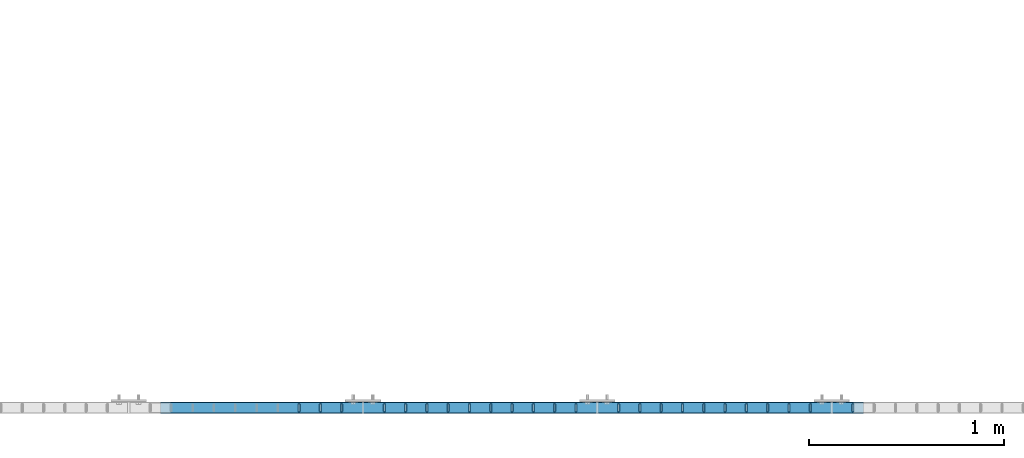
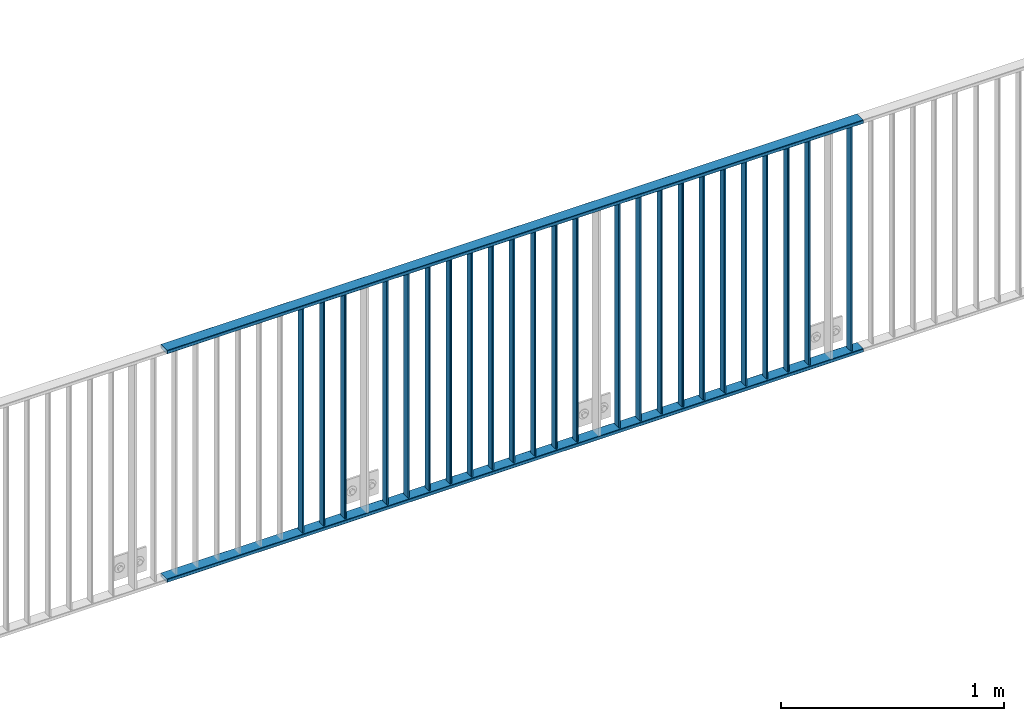
# One storey, part 29 of 156: 26 beams, 1 element without a shape of its own.
"""IFC2X3 building model written with IfcOpenShell, lengths in millimetres."""

from ifc_helpers import new_model, si_unit, frame, origin_with_axes, origin_2d_with_axis, place, context, subcontext, project, spatial, hollow_rectangle, extrude, clip, halfspace, material, type_object, element, aggregate, save


model = new_model("IFC2X3")

# Units and contexts
model_context = context("Model", 3, precision=1e-05, world=origin_with_axes())
body_context = subcontext(model_context, "Body", "Model", "MODEL_VIEW")
ifc_project = project(units=[si_unit("LENGTHUNIT", "METRE", prefix="MILLI"), si_unit("AREAUNIT", "SQUARE_METRE"), si_unit("VOLUMEUNIT", "CUBIC_METRE"), si_unit("MASSUNIT", "GRAM", prefix="KILO"), si_unit("TIMEUNIT", "SECOND"), si_unit("PLANEANGLEUNIT", "RADIAN"), si_unit("SOLIDANGLEUNIT", "STERADIAN"), si_unit("THERMODYNAMICTEMPERATUREUNIT", "DEGREE_CELSIUS"), si_unit("LUMINOUSINTENSITYUNIT", "LUMEN")], contexts=[model_context])

# Site, building, storey
site_placement = place(None, origin_with_axes())
site = spatial("IfcSite", under=ifc_project, at=site_placement, CompositionType="ELEMENT")
building_placement = place(site_placement, origin_with_axes())
building = spatial("IfcBuilding", under=site, at=building_placement, Name="Undefined", CompositionType="ELEMENT")
storey_placement = place(building_placement, origin_with_axes())
storey = spatial("IfcBuildingStorey", under=building, at=storey_placement, Name="Undefined", CompositionType="ELEMENT", Elevation=0.0)

# Assembly, beams
assembly_placement = place(storey_placement, origin_with_axes())
assembly = element("IfcElementAssembly", 1, at=assembly_placement, inside=storey, AssemblyPlace="NOTDEFINED", PredefinedType="RIGID_FRAME")
ifc_material = material(Name="STEEL/S235JR")
beam_type_1 = type_object("IfcBeamType", Name="K60/20/2", PredefinedType="NOTDEFINED")
beam_1_placement = place(assembly_placement, frame((39563.0399999997, 8480.00209045411, 2740.0), z_axis=(0.0, 1.0, 0.0), x_axis=(1.0, 0.0, 0.0)))
beam_1 = element("IfcBeam", 2, at=beam_1_placement, type_object=beam_type_1, material=ifc_material, ObjectType="K60/20/2", context=body_context, shape_type="SweptSolid", body=[
    extrude(hollow_rectangle(XDim=20.0, YDim=60.0, WallThickness=2.0, InnerFilletRadius=2.0, OuterFilletRadius=4.0, at=origin_2d_with_axis()), frame((3600.0, 0.0, 0.0), z_axis=(-1.0, 0.0, 0.0), x_axis=(0.0, -1.0, 0.0)), (0.0, 0.0, 1.0), 3600.0),
])
beam_2_placement = place(assembly_placement, frame((39563.0399999997, 8479.98209037835, 3990.0), z_axis=(0.0, 1.0, 0.0), x_axis=(1.0, 0.0, 0.0)))
beam_2 = element("IfcBeam", 3, at=beam_2_placement, type_object=beam_type_1, material=ifc_material, ObjectType="K60/20/2", context=body_context, shape_type="SweptSolid", body=[
    extrude(hollow_rectangle(XDim=20.0, YDim=60.0, WallThickness=2.0, InnerFilletRadius=2.0, OuterFilletRadius=4.0, at=origin_2d_with_axis()), frame((3600.0, 0.0, 0.0), z_axis=(-1.0, 0.0, 0.0), x_axis=(0.0, -1.0, 0.0)), (0.0, 0.0, 1.0), 3600.0),
])
beam_type_2 = type_object("IfcBeamType", Name="K40/10/1.5", PredefinedType="NOTDEFINED")
beam_3_placement = place(assembly_placement, frame((43109.089999999, 8480.00209765299, 3980.00000000003), z_axis=(0.0, 1.0, 0.0), x_axis=(0.0, 0.0, -1.0)))
beam_3 = element("IfcBeam", 4, at=beam_3_placement, type_object=beam_type_2, material=ifc_material, ObjectType="K40/10/1.5", context=body_context, shape_type="Clipping", body=[
    clip(extrude(hollow_rectangle(XDim=10.0, YDim=40.0, WallThickness=1.5, InnerFilletRadius=1.5, OuterFilletRadius=3.0, at=origin_2d_with_axis()), frame((1230.0, 0.0, 0.0), z_axis=(-1.0, 0.0, 0.0), x_axis=(0.0, -1.0, 0.0)), (0.0, 0.0, 1.0), 1230.0), halfspace(frame((-6.99999999997453, -4.34248751950508, 47.3810900558092), z_axis=(-1.0, 0.0, 0.0), x_axis=(0.0, 0.7683548141934, -0.640024124159258)), False)),
])
beam_4_placement = place(assembly_placement, frame((42890.899999999, 8480.00209765299, 3980.00000000003), z_axis=(0.0, 1.0, 0.0), x_axis=(0.0, 0.0, -1.0)))
beam_4 = element("IfcBeam", 5, at=beam_4_placement, type_object=beam_type_2, material=ifc_material, ObjectType="K40/10/1.5", context=body_context, shape_type="Clipping", body=[
    clip(extrude(hollow_rectangle(XDim=10.0, YDim=40.0, WallThickness=1.5, InnerFilletRadius=1.5, OuterFilletRadius=3.0, at=origin_2d_with_axis()), frame((1230.0, 0.0, 0.0), z_axis=(-1.0, 0.0, 0.0), x_axis=(0.0, -1.0, 0.0)), (0.0, 0.0, 1.0), 1230.0), halfspace(frame((-6.99999999997453, -4.34248751950508, 47.3810900558092), z_axis=(-1.0, 0.0, 0.0), x_axis=(0.0, 0.7683548141934, -0.640024124159258)), False)),
])
beam_5_placement = place(assembly_placement, frame((42781.809999999, 8480.00209765299, 3980.00000000003), z_axis=(0.0, 1.0, 0.0), x_axis=(0.0, 0.0, -1.0)))
beam_5 = element("IfcBeam", 6, at=beam_5_placement, type_object=beam_type_2, material=ifc_material, ObjectType="K40/10/1.5", context=body_context, shape_type="Clipping", body=[
    clip(extrude(hollow_rectangle(XDim=10.0, YDim=40.0, WallThickness=1.5, InnerFilletRadius=1.5, OuterFilletRadius=3.0, at=origin_2d_with_axis()), frame((1230.0, 0.0, 0.0), z_axis=(-1.0, 0.0, 0.0), x_axis=(0.0, -1.0, 0.0)), (0.0, 0.0, 1.0), 1230.0), halfspace(frame((-6.99999999997453, -4.34248751950508, 47.3810900558092), z_axis=(-1.0, 0.0, 0.0), x_axis=(0.0, 0.7683548141934, -0.640024124159258)), False)),
])
beam_6_placement = place(assembly_placement, frame((42672.719999999, 8480.00209765299, 3980.00000000003), z_axis=(0.0, 1.0, 0.0), x_axis=(0.0, 0.0, -1.0)))
beam_6 = element("IfcBeam", 7, at=beam_6_placement, type_object=beam_type_2, material=ifc_material, ObjectType="K40/10/1.5", context=body_context, shape_type="Clipping", body=[
    clip(extrude(hollow_rectangle(XDim=10.0, YDim=40.0, WallThickness=1.5, InnerFilletRadius=1.5, OuterFilletRadius=3.0, at=origin_2d_with_axis()), frame((1230.0, 0.0, 0.0), z_axis=(-1.0, 0.0, 0.0), x_axis=(0.0, -1.0, 0.0)), (0.0, 0.0, 1.0), 1230.0), halfspace(frame((-6.99999999997453, -4.34248751950508, 47.3810900558092), z_axis=(-1.0, 0.0, 0.0), x_axis=(0.0, 0.7683548141934, -0.640024124159258)), False)),
])
beam_7_placement = place(assembly_placement, frame((42563.629999999, 8480.00209765299, 3980.00000000003), z_axis=(0.0, 1.0, 0.0), x_axis=(0.0, 0.0, -1.0)))
beam_7 = element("IfcBeam", 8, at=beam_7_placement, type_object=beam_type_2, material=ifc_material, ObjectType="K40/10/1.5", context=body_context, shape_type="Clipping", body=[
    clip(extrude(hollow_rectangle(XDim=10.0, YDim=40.0, WallThickness=1.5, InnerFilletRadius=1.5, OuterFilletRadius=3.0, at=origin_2d_with_axis()), frame((1230.0, 0.0, 0.0), z_axis=(-1.0, 0.0, 0.0), x_axis=(0.0, -1.0, 0.0)), (0.0, 0.0, 1.0), 1230.0), halfspace(frame((-6.99999999997453, -4.34248751950508, 47.3810900558092), z_axis=(-1.0, 0.0, 0.0), x_axis=(0.0, 0.7683548141934, -0.640024124159258)), False)),
])
beam_8_placement = place(assembly_placement, frame((42454.539999999, 8480.00209765299, 3980.00000000003), z_axis=(0.0, 1.0, 0.0), x_axis=(0.0, 0.0, -1.0)))
beam_8 = element("IfcBeam", 9, at=beam_8_placement, type_object=beam_type_2, material=ifc_material, ObjectType="K40/10/1.5", context=body_context, shape_type="Clipping", body=[
    clip(extrude(hollow_rectangle(XDim=10.0, YDim=40.0, WallThickness=1.5, InnerFilletRadius=1.5, OuterFilletRadius=3.0, at=origin_2d_with_axis()), frame((1230.0, 0.0, 0.0), z_axis=(-1.0, 0.0, 0.0), x_axis=(0.0, -1.0, 0.0)), (0.0, 0.0, 1.0), 1230.0), halfspace(frame((-6.99999999997453, -4.34248751950508, 47.3810900558092), z_axis=(-1.0, 0.0, 0.0), x_axis=(0.0, 0.7683548141934, -0.640024124159258)), False)),
])
beam_9_placement = place(assembly_placement, frame((42345.449999999, 8480.00209765299, 3980.00000000003), z_axis=(0.0, 1.0, 0.0), x_axis=(0.0, 0.0, -1.0)))
beam_9 = element("IfcBeam", 10, at=beam_9_placement, type_object=beam_type_2, material=ifc_material, ObjectType="K40/10/1.5", context=body_context, shape_type="Clipping", body=[
    clip(extrude(hollow_rectangle(XDim=10.0, YDim=40.0, WallThickness=1.5, InnerFilletRadius=1.5, OuterFilletRadius=3.0, at=origin_2d_with_axis()), frame((1230.0, 0.0, 0.0), z_axis=(-1.0, 0.0, 0.0), x_axis=(0.0, -1.0, 0.0)), (0.0, 0.0, 1.0), 1230.0), halfspace(frame((-6.99999999997453, -4.34248751950508, 47.3810900558092), z_axis=(-1.0, 0.0, 0.0), x_axis=(0.0, 0.7683548141934, -0.640024124159258)), False)),
])
beam_10_placement = place(assembly_placement, frame((42236.359999999, 8480.00209765299, 3980.00000000003), z_axis=(0.0, 1.0, 0.0), x_axis=(0.0, 0.0, -1.0)))
beam_10 = element("IfcBeam", 11, at=beam_10_placement, type_object=beam_type_2, material=ifc_material, ObjectType="K40/10/1.5", context=body_context, shape_type="Clipping", body=[
    clip(extrude(hollow_rectangle(XDim=10.0, YDim=40.0, WallThickness=1.5, InnerFilletRadius=1.5, OuterFilletRadius=3.0, at=origin_2d_with_axis()), frame((1230.0, 0.0, 0.0), z_axis=(-1.0, 0.0, 0.0), x_axis=(0.0, -1.0, 0.0)), (0.0, 0.0, 1.0), 1230.0), halfspace(frame((-6.99999999997453, -4.34248751950508, 47.3810900558092), z_axis=(-1.0, 0.0, 0.0), x_axis=(0.0, 0.7683548141934, -0.640024124159258)), False)),
])
beam_11_placement = place(assembly_placement, frame((42127.269999999, 8480.00209765299, 3980.00000000003), z_axis=(0.0, 1.0, 0.0), x_axis=(0.0, 0.0, -1.0)))
beam_11 = element("IfcBeam", 12, at=beam_11_placement, type_object=beam_type_2, material=ifc_material, ObjectType="K40/10/1.5", context=body_context, shape_type="Clipping", body=[
    clip(extrude(hollow_rectangle(XDim=10.0, YDim=40.0, WallThickness=1.5, InnerFilletRadius=1.5, OuterFilletRadius=3.0, at=origin_2d_with_axis()), frame((1230.0, 0.0, 0.0), z_axis=(-1.0, 0.0, 0.0), x_axis=(0.0, -1.0, 0.0)), (0.0, 0.0, 1.0), 1230.0), halfspace(frame((-6.99999999997453, -4.34248751950508, 47.3810900558092), z_axis=(-1.0, 0.0, 0.0), x_axis=(0.0, 0.7683548141934, -0.640024124159258)), False)),
])
beam_12_placement = place(assembly_placement, frame((42018.179999999, 8480.00209765299, 3980.00000000003), z_axis=(0.0, 1.0, 0.0), x_axis=(0.0, 0.0, -1.0)))
beam_12 = element("IfcBeam", 13, at=beam_12_placement, type_object=beam_type_2, material=ifc_material, ObjectType="K40/10/1.5", context=body_context, shape_type="Clipping", body=[
    clip(extrude(hollow_rectangle(XDim=10.0, YDim=40.0, WallThickness=1.5, InnerFilletRadius=1.5, OuterFilletRadius=3.0, at=origin_2d_with_axis()), frame((1230.0, 0.0, 0.0), z_axis=(-1.0, 0.0, 0.0), x_axis=(0.0, -1.0, 0.0)), (0.0, 0.0, 1.0), 1230.0), halfspace(frame((-6.99999999997453, -4.34248751950508, 47.3810900558092), z_axis=(-1.0, 0.0, 0.0), x_axis=(0.0, 0.7683548141934, -0.640024124159258)), False)),
])
beam_13_placement = place(assembly_placement, frame((41909.089999999, 8480.00209765299, 3980.00000000003), z_axis=(0.0, 1.0, 0.0), x_axis=(0.0, 0.0, -1.0)))
beam_13 = element("IfcBeam", 14, at=beam_13_placement, type_object=beam_type_2, material=ifc_material, ObjectType="K40/10/1.5", context=body_context, shape_type="Clipping", body=[
    clip(extrude(hollow_rectangle(XDim=10.0, YDim=40.0, WallThickness=1.5, InnerFilletRadius=1.5, OuterFilletRadius=3.0, at=origin_2d_with_axis()), frame((1230.0, 0.0, 0.0), z_axis=(-1.0, 0.0, 0.0), x_axis=(0.0, -1.0, 0.0)), (0.0, 0.0, 1.0), 1230.0), halfspace(frame((-6.99999999997453, -4.34248751950508, 47.3810900558092), z_axis=(-1.0, 0.0, 0.0), x_axis=(0.0, 0.7683548141934, -0.640024124159258)), False)),
])
beam_14_placement = place(assembly_placement, frame((41690.899999999, 8480.00209765299, 3980.00000000003), z_axis=(0.0, 1.0, 0.0), x_axis=(0.0, 0.0, -1.0)))
beam_14 = element("IfcBeam", 15, at=beam_14_placement, type_object=beam_type_2, material=ifc_material, ObjectType="K40/10/1.5", context=body_context, shape_type="Clipping", body=[
    clip(extrude(hollow_rectangle(XDim=10.0, YDim=40.0, WallThickness=1.5, InnerFilletRadius=1.5, OuterFilletRadius=3.0, at=origin_2d_with_axis()), frame((1230.0, 0.0, 0.0), z_axis=(-1.0, 0.0, 0.0), x_axis=(0.0, -1.0, 0.0)), (0.0, 0.0, 1.0), 1230.0), halfspace(frame((-6.99999999997453, -4.34248751950508, 47.3810900558092), z_axis=(-1.0, 0.0, 0.0), x_axis=(0.0, 0.7683548141934, -0.640024124159258)), False)),
])
beam_15_placement = place(assembly_placement, frame((41581.809999999, 8480.00209765299, 3980.00000000003), z_axis=(0.0, 1.0, 0.0), x_axis=(0.0, 0.0, -1.0)))
beam_15 = element("IfcBeam", 16, at=beam_15_placement, type_object=beam_type_2, material=ifc_material, ObjectType="K40/10/1.5", context=body_context, shape_type="Clipping", body=[
    clip(extrude(hollow_rectangle(XDim=10.0, YDim=40.0, WallThickness=1.5, InnerFilletRadius=1.5, OuterFilletRadius=3.0, at=origin_2d_with_axis()), frame((1230.0, 0.0, 0.0), z_axis=(-1.0, 0.0, 0.0), x_axis=(0.0, -1.0, 0.0)), (0.0, 0.0, 1.0), 1230.0), halfspace(frame((-6.99999999997453, -4.34248751950508, 47.3810900558092), z_axis=(-1.0, 0.0, 0.0), x_axis=(0.0, 0.7683548141934, -0.640024124159258)), False)),
])
beam_16_placement = place(assembly_placement, frame((41472.719999999, 8480.00209765299, 3980.00000000003), z_axis=(0.0, 1.0, 0.0), x_axis=(0.0, 0.0, -1.0)))
beam_16 = element("IfcBeam", 17, at=beam_16_placement, type_object=beam_type_2, material=ifc_material, ObjectType="K40/10/1.5", context=body_context, shape_type="Clipping", body=[
    clip(extrude(hollow_rectangle(XDim=10.0, YDim=40.0, WallThickness=1.5, InnerFilletRadius=1.5, OuterFilletRadius=3.0, at=origin_2d_with_axis()), frame((1230.0, 0.0, 0.0), z_axis=(-1.0, 0.0, 0.0), x_axis=(0.0, -1.0, 0.0)), (0.0, 0.0, 1.0), 1230.0), halfspace(frame((-6.99999999997453, -4.34248751950508, 47.3810900558092), z_axis=(-1.0, 0.0, 0.0), x_axis=(0.0, 0.7683548141934, -0.640024124159258)), False)),
])
beam_17_placement = place(assembly_placement, frame((41363.629999999, 8480.00209765299, 3980.00000000003), z_axis=(0.0, 1.0, 0.0), x_axis=(0.0, 0.0, -1.0)))
beam_17 = element("IfcBeam", 18, at=beam_17_placement, type_object=beam_type_2, material=ifc_material, ObjectType="K40/10/1.5", context=body_context, shape_type="Clipping", body=[
    clip(extrude(hollow_rectangle(XDim=10.0, YDim=40.0, WallThickness=1.5, InnerFilletRadius=1.5, OuterFilletRadius=3.0, at=origin_2d_with_axis()), frame((1230.0, 0.0, 0.0), z_axis=(-1.0, 0.0, 0.0), x_axis=(0.0, -1.0, 0.0)), (0.0, 0.0, 1.0), 1230.0), halfspace(frame((-6.99999999997453, -4.34248751950508, 47.3810900558092), z_axis=(-1.0, 0.0, 0.0), x_axis=(0.0, 0.7683548141934, -0.640024124159258)), False)),
])
beam_18_placement = place(assembly_placement, frame((41254.539999999, 8480.00209765299, 3980.00000000003), z_axis=(0.0, 1.0, 0.0), x_axis=(0.0, 0.0, -1.0)))
beam_18 = element("IfcBeam", 19, at=beam_18_placement, type_object=beam_type_2, material=ifc_material, ObjectType="K40/10/1.5", context=body_context, shape_type="Clipping", body=[
    clip(extrude(hollow_rectangle(XDim=10.0, YDim=40.0, WallThickness=1.5, InnerFilletRadius=1.5, OuterFilletRadius=3.0, at=origin_2d_with_axis()), frame((1230.0, 0.0, 0.0), z_axis=(-1.0, 0.0, 0.0), x_axis=(0.0, -1.0, 0.0)), (0.0, 0.0, 1.0), 1230.0), halfspace(frame((-6.99999999997453, -4.34248751950508, 47.3810900558092), z_axis=(-1.0, 0.0, 0.0), x_axis=(0.0, 0.7683548141934, -0.640024124159258)), False)),
])
beam_19_placement = place(assembly_placement, frame((41145.449999999, 8480.00209765299, 3980.00000000003), z_axis=(0.0, 1.0, 0.0), x_axis=(0.0, 0.0, -1.0)))
beam_19 = element("IfcBeam", 20, at=beam_19_placement, type_object=beam_type_2, material=ifc_material, ObjectType="K40/10/1.5", context=body_context, shape_type="Clipping", body=[
    clip(extrude(hollow_rectangle(XDim=10.0, YDim=40.0, WallThickness=1.5, InnerFilletRadius=1.5, OuterFilletRadius=3.0, at=origin_2d_with_axis()), frame((1230.0, 0.0, 0.0), z_axis=(-1.0, 0.0, 0.0), x_axis=(0.0, -1.0, 0.0)), (0.0, 0.0, 1.0), 1230.0), halfspace(frame((-6.99999999997453, -4.34248751950508, 47.3810900558092), z_axis=(-1.0, 0.0, 0.0), x_axis=(0.0, 0.7683548141934, -0.640024124159258)), False)),
])
beam_20_placement = place(assembly_placement, frame((41036.359999999, 8480.00209765299, 3980.00000000003), z_axis=(0.0, 1.0, 0.0), x_axis=(0.0, 0.0, -1.0)))
beam_20 = element("IfcBeam", 21, at=beam_20_placement, type_object=beam_type_2, material=ifc_material, ObjectType="K40/10/1.5", context=body_context, shape_type="Clipping", body=[
    clip(extrude(hollow_rectangle(XDim=10.0, YDim=40.0, WallThickness=1.5, InnerFilletRadius=1.5, OuterFilletRadius=3.0, at=origin_2d_with_axis()), frame((1230.0, 0.0, 0.0), z_axis=(-1.0, 0.0, 0.0), x_axis=(0.0, -1.0, 0.0)), (0.0, 0.0, 1.0), 1230.0), halfspace(frame((-6.99999999997453, -4.34248751950508, 47.3810900558092), z_axis=(-1.0, 0.0, 0.0), x_axis=(0.0, 0.7683548141934, -0.640024124159258)), False)),
])
beam_21_placement = place(assembly_placement, frame((40927.269999999, 8480.00209765299, 3980.00000000003), z_axis=(0.0, 1.0, 0.0), x_axis=(0.0, 0.0, -1.0)))
beam_21 = element("IfcBeam", 22, at=beam_21_placement, type_object=beam_type_2, material=ifc_material, ObjectType="K40/10/1.5", context=body_context, shape_type="Clipping", body=[
    clip(extrude(hollow_rectangle(XDim=10.0, YDim=40.0, WallThickness=1.5, InnerFilletRadius=1.5, OuterFilletRadius=3.0, at=origin_2d_with_axis()), frame((1230.0, 0.0, 0.0), z_axis=(-1.0, 0.0, 0.0), x_axis=(0.0, -1.0, 0.0)), (0.0, 0.0, 1.0), 1230.0), halfspace(frame((-6.99999999997453, -4.34248751950508, 47.3810900558092), z_axis=(-1.0, 0.0, 0.0), x_axis=(0.0, 0.7683548141934, -0.640024124159258)), False)),
])
beam_22_placement = place(assembly_placement, frame((40818.179999999, 8480.00209765299, 3980.00000000003), z_axis=(0.0, 1.0, 0.0), x_axis=(0.0, 0.0, -1.0)))
beam_22 = element("IfcBeam", 23, at=beam_22_placement, type_object=beam_type_2, material=ifc_material, ObjectType="K40/10/1.5", context=body_context, shape_type="Clipping", body=[
    clip(extrude(hollow_rectangle(XDim=10.0, YDim=40.0, WallThickness=1.5, InnerFilletRadius=1.5, OuterFilletRadius=3.0, at=origin_2d_with_axis()), frame((1230.0, 0.0, 0.0), z_axis=(-1.0, 0.0, 0.0), x_axis=(0.0, -1.0, 0.0)), (0.0, 0.0, 1.0), 1230.0), halfspace(frame((-6.99999999997453, -4.34248751950508, 47.3810900558092), z_axis=(-1.0, 0.0, 0.0), x_axis=(0.0, 0.7683548141934, -0.640024124159258)), False)),
])
beam_23_placement = place(assembly_placement, frame((40709.089999999, 8480.00209765299, 3980.00000000003), z_axis=(0.0, 1.0, 0.0), x_axis=(0.0, 0.0, -1.0)))
beam_23 = element("IfcBeam", 24, at=beam_23_placement, type_object=beam_type_2, material=ifc_material, ObjectType="K40/10/1.5", context=body_context, shape_type="Clipping", body=[
    clip(extrude(hollow_rectangle(XDim=10.0, YDim=40.0, WallThickness=1.5, InnerFilletRadius=1.5, OuterFilletRadius=3.0, at=origin_2d_with_axis()), frame((1230.0, 0.0, 0.0), z_axis=(-1.0, 0.0, 0.0), x_axis=(0.0, -1.0, 0.0)), (0.0, 0.0, 1.0), 1230.0), halfspace(frame((-6.99999999997453, -4.34248751950508, 47.3810900558092), z_axis=(-1.0, 0.0, 0.0), x_axis=(0.0, 0.7683548141934, -0.640024124159258)), False)),
])
beam_24_placement = place(assembly_placement, frame((40490.899999999, 8480.00209765299, 3980.00000000003), z_axis=(0.0, 1.0, 0.0), x_axis=(0.0, 0.0, -1.0)))
beam_24 = element("IfcBeam", 25, at=beam_24_placement, type_object=beam_type_2, material=ifc_material, ObjectType="K40/10/1.5", context=body_context, shape_type="Clipping", body=[
    clip(extrude(hollow_rectangle(XDim=10.0, YDim=40.0, WallThickness=1.5, InnerFilletRadius=1.5, OuterFilletRadius=3.0, at=origin_2d_with_axis()), frame((1230.0, 0.0, 0.0), z_axis=(-1.0, 0.0, 0.0), x_axis=(0.0, -1.0, 0.0)), (0.0, 0.0, 1.0), 1230.0), halfspace(frame((-6.99999999997453, -4.34248751950508, 47.3810900558092), z_axis=(-1.0, 0.0, 0.0), x_axis=(0.0, 0.7683548141934, -0.640024124159258)), False)),
])
beam_25_placement = place(assembly_placement, frame((40381.809999999, 8480.00209765299, 3980.00000000003), z_axis=(0.0, 1.0, 0.0), x_axis=(0.0, 0.0, -1.0)))
beam_25 = element("IfcBeam", 26, at=beam_25_placement, type_object=beam_type_2, material=ifc_material, ObjectType="K40/10/1.5", context=body_context, shape_type="Clipping", body=[
    clip(extrude(hollow_rectangle(XDim=10.0, YDim=40.0, WallThickness=1.5, InnerFilletRadius=1.5, OuterFilletRadius=3.0, at=origin_2d_with_axis()), frame((1230.0, 0.0, 0.0), z_axis=(-1.0, 0.0, 0.0), x_axis=(0.0, -1.0, 0.0)), (0.0, 0.0, 1.0), 1230.0), halfspace(frame((-6.99999999997453, -4.34248751950508, 47.3810900558092), z_axis=(-1.0, 0.0, 0.0), x_axis=(0.0, 0.7683548141934, -0.640024124159258)), False)),
])
beam_26_placement = place(assembly_placement, frame((40272.719999999, 8480.00209765299, 3980.00000000003), z_axis=(0.0, 1.0, 0.0), x_axis=(0.0, 0.0, -1.0)))
beam_26 = element("IfcBeam", 27, at=beam_26_placement, type_object=beam_type_2, material=ifc_material, ObjectType="K40/10/1.5", context=body_context, shape_type="Clipping", body=[
    clip(extrude(hollow_rectangle(XDim=10.0, YDim=40.0, WallThickness=1.5, InnerFilletRadius=1.5, OuterFilletRadius=3.0, at=origin_2d_with_axis()), frame((1230.0, 0.0, 0.0), z_axis=(-1.0, 0.0, 0.0), x_axis=(0.0, -1.0, 0.0)), (0.0, 0.0, 1.0), 1230.0), halfspace(frame((-6.99999999997453, -4.34248751950508, 47.3810900558092), z_axis=(-1.0, 0.0, 0.0), x_axis=(0.0, 0.7683548141934, -0.640024124159258)), False)),
])
aggregate(assembly, [beam_1, beam_2, beam_3, beam_4, beam_5, beam_6, beam_7, beam_8, beam_9, beam_10, beam_11, beam_12, beam_13, beam_14, beam_15, beam_16, beam_17, beam_18, beam_19, beam_20, beam_21, beam_22, beam_23, beam_24, beam_25, beam_26])

save(model, "model.ifc")
